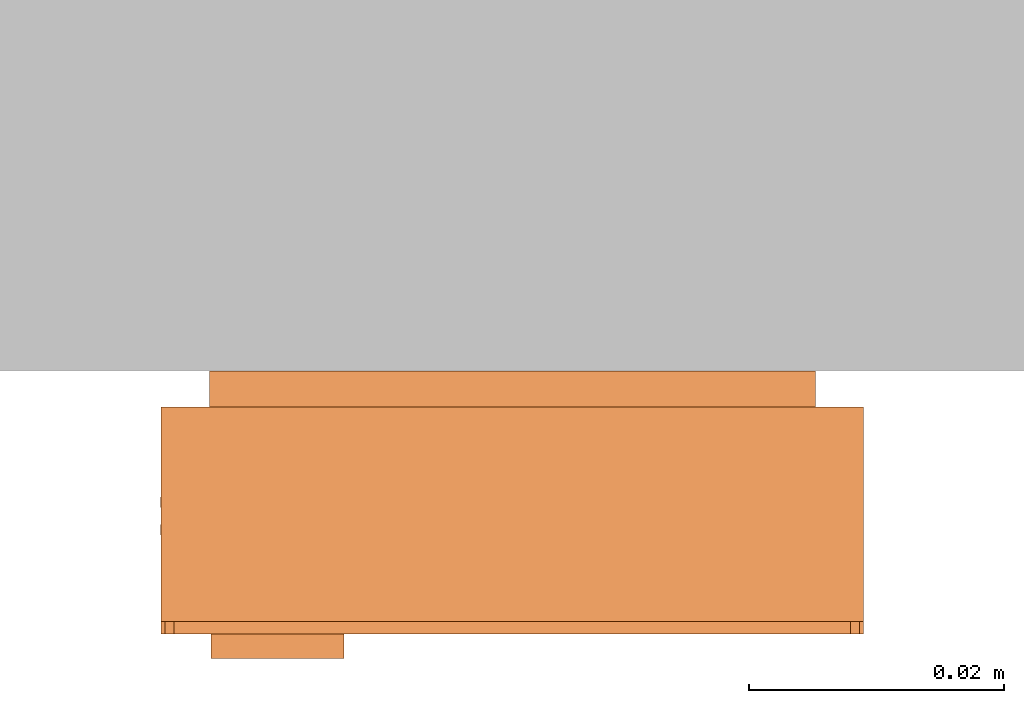
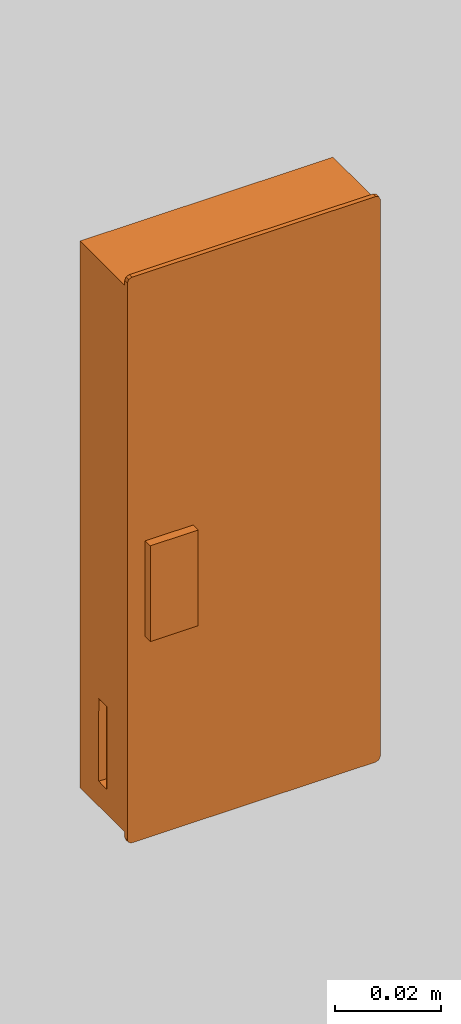
# One storey, part 2 of 2: 1 proxy.
"""IFC2X3 building model written with IfcOpenShell, lengths in metres."""

from ifc_helpers import new_model, entity, si_unit, converted_unit, derived_unit, direction, frame, origin, place, context, subcontext, project, spatial, faceted_brep, source, transform, mapped, material, type_object, type_shapes, element, save


model = new_model("IFC2X3")

# Units and contexts
model_context = context("Model", 3, precision=1e-05, world=origin(), true_north=direction((6.12303176911189e-17, 1.0)))
body_context = subcontext(model_context, "Body", "Model", "MODEL_VIEW")
ifc_project = project(units=[si_unit("LENGTHUNIT", "METRE"), si_unit("AREAUNIT", "SQUARE_METRE"), si_unit("VOLUMEUNIT", "CUBIC_METRE"), converted_unit("PLANEANGLEUNIT", "DEGREE", entity("IfcRatioMeasure", 0.0174532925199433), si_unit("PLANEANGLEUNIT", "RADIAN"), dimensions=[0, 0, 0, 0, 0, 0, 0]), si_unit("MASSUNIT", "GRAM", prefix="KILO"), si_unit("TIMEUNIT", "SECOND"), si_unit("FREQUENCYUNIT", "HERTZ"), si_unit("THERMODYNAMICTEMPERATUREUNIT", "DEGREE_CELSIUS"), derived_unit("THERMALTRANSMITTANCEUNIT", [(si_unit("MASSUNIT", "GRAM", prefix="KILO"), 1), (si_unit("THERMODYNAMICTEMPERATUREUNIT", "KELVIN"), -1), (si_unit("TIMEUNIT", "SECOND"), -3)]), derived_unit("VOLUMETRICFLOWRATEUNIT", [(si_unit("LENGTHUNIT", "METRE"), 3), (si_unit("TIMEUNIT", "SECOND"), -1)]), si_unit("ELECTRICCURRENTUNIT", "AMPERE"), si_unit("ELECTRICVOLTAGEUNIT", "VOLT"), si_unit("POWERUNIT", "WATT"), si_unit("FORCEUNIT", "NEWTON", prefix="KILO"), si_unit("ILLUMINANCEUNIT", "LUX"), si_unit("LUMINOUSFLUXUNIT", "LUMEN"), si_unit("LUMINOUSINTENSITYUNIT", "CANDELA"), derived_unit("USERDEFINED", [(si_unit("MASSUNIT", "GRAM", prefix="KILO"), -1), (si_unit("LENGTHUNIT", "METRE"), -2), (si_unit("TIMEUNIT", "SECOND"), 3), (si_unit("LUMINOUSFLUXUNIT", "LUMEN"), 1)]), derived_unit("LINEARVELOCITYUNIT", [(si_unit("LENGTHUNIT", "METRE"), 1), (si_unit("TIMEUNIT", "SECOND"), -1)]), si_unit("PRESSUREUNIT", "PASCAL"), derived_unit("USERDEFINED", [(si_unit("LENGTHUNIT", "METRE"), -2), (si_unit("MASSUNIT", "GRAM", prefix="KILO"), 1), (si_unit("TIMEUNIT", "SECOND"), -2)])], contexts=[model_context])

# Site, building, storey
site_placement = place(None, origin())
site = spatial("IfcSite", under=ifc_project, at=site_placement, CompositionType="ELEMENT")
building_placement = place(site_placement, origin())
building = spatial("IfcBuilding", under=site, at=building_placement, CompositionType="ELEMENT")
storey_placement = place(building_placement, origin())
storey = spatial("IfcBuildingStorey", under=building, at=storey_placement, Name="Ebene 0", CompositionType="ELEMENT", Elevation=0.0)

# Proxy
ifc_material = material(Name="Color aluminum")
building_element_proxy_type = type_object("IfcBuildingElementProxyType", Name="123926", PredefinedType="NOTDEFINED", material=ifc_material)
shared_shape = source(origin(), body_context, "Body", "Brep", [
    faceted_brep([(-0.0131999998092463, -0.0186000041961923, 0.0224999999999981), (-0.0131999998092463, -0.00859402157550463, 0.0224999999999981), (-0.0131999998092464, 0.00339999580380773, 0.0224999999999981), (-0.0236053290845589, 0.00339999580380773, 0.0224999999999981), (-0.0236053290845589, -0.0186000041961923, 0.0224999999999981), (-0.0131999998092463, -0.0186000041961923, 0.0205999999999981), (-0.0236053290845589, -0.0186000041961923, 0.0205999999999981), (-0.0236053290845589, 0.00339999580380772, 0.0205999999999981), (-0.0131999998092464, 0.00339999580380773, 0.0205999999999981), (-0.0131999998092463, -0.00859402157550463, 0.0205999999999981)], [[[0, 1, 2, 3, 4]], [[5, 6, 7, 8, 9]], [[1, 0, 5, 9]], [[2, 1, 9, 8]], [[3, 2, 8, 7]], [[4, 3, 7, 6]], [[0, 4, 6, 5]]]),
    faceted_brep([(0.0275000000000188, 0.0639999999999747, 0.0205999999999981), (0.0272071067812053, 0.0647071067811613, 0.0205999999999981), (0.0265000000000188, 0.0649999999999747, 0.0205999999999981), (-0.0264999999999813, 0.0649999999999747, 0.0205999999999981), (-0.0272071067811678, 0.0647071067811613, 0.0205999999999981), (-0.0274999999999812, 0.0639999999999747, 0.0205999999999981), (-0.0274999999999812, -0.0640000000000253, 0.0205999999999981), (-0.0272071067811678, -0.0647071067812118, 0.0205999999999981), (-0.0264999999999812, -0.0650000000000253, 0.0205999999999981), (0.0265000000000188, -0.0650000000000253, 0.0205999999999981), (0.0272071067812053, -0.0647071067812118, 0.0205999999999981), (0.0275000000000188, -0.0640000000000253, 0.0205999999999981), (-0.0274999999999813, 0.0639999999999747, 0.0195999999999981), (-0.0272071067811678, 0.0647071067811613, 0.0195999999999981), (-0.0264999999999813, 0.0649999999999747, 0.0195999999999981), (0.0265000000000188, 0.0649999999999747, 0.0195999999999981), (0.0272071067812053, 0.0647071067811613, 0.0195999999999981), (0.0275000000000188, 0.0639999999999747, 0.0195999999999981), (0.0275000000000188, -0.0640000000000253, 0.0195999999999981), (0.0272071067812053, -0.0647071067812118, 0.0195999999999981), (0.0265000000000188, -0.0650000000000253, 0.0195999999999981), (-0.0264999999999812, -0.0650000000000253, 0.0195999999999981), (-0.0272071067811678, -0.0647071067812118, 0.0195999999999981), (-0.0274999999999812, -0.0640000000000253, 0.0195999999999981)], [[[0, 1, 2, 3, 4, 5, 6, 7, 8, 9, 10, 11]], [[12, 13, 14, 15, 16, 17, 18, 19, 20, 21, 22, 23]], [[3, 2, 15, 14]], [[3, 14, 13, 4]], [[13, 12, 5, 4]], [[6, 5, 12, 23]], [[6, 23, 22, 7]], [[22, 21, 8, 7]], [[9, 8, 21, 20]], [[9, 20, 19, 10]], [[19, 18, 11, 10]], [[0, 11, 18, 17]], [[0, 17, 16, 1]], [[16, 15, 2, 1]]]),
    faceted_brep([(0.00595327290728861, 0.0323987510346145, 0.00199999999999813), (0.00669715479099942, 0.0323171332573382, 0.00199999999999813), (0.00739780763980555, 0.0320542505763938, 0.00199999999999813), (0.00801178551193202, 0.0316264037685061, 0.00199999999999813), (0.00850101699022983, 0.0310601226730038, 0.00199999999999813), (0.00883516590699932, 0.0303905211348467, 0.00199999999999813), (0.00899351242301216, 0.0296591196723466, 0.00199999999999813), (0.00896623781915989, 0.0289112708811693, 0.00199999999999813), (0.00875503333362548, 0.0281933472196489, 0.00199999999999813), (0.00837299529192415, 0.0275498655546625, 0.00199999999999813), (0.00784381303256908, 0.0270207267686484, 0.00199999999999813), (0.00720029998330481, 0.0266387415936648, 0.00199999999999813), (0.00648235897263965, 0.026427596090076, 0.00199999999999813), (0.00573450794323291, 0.0264003829260567, 0.00199999999999813), (0.00500311949220646, 0.0265587895300408, 0.00199999999999813), (0.00433354540841312, 0.026892993456997, 0.00199999999999813), (0.00376730450778022, 0.0273822714566364, 0.00199999999999813), (0.0033395081428717, 0.0279962844765732, 0.00199999999999813), (-0.00046539388874918, 0.0281909146064386, 0.00199999999999813), (-0.00426179813546751, 0.0278707972011297, 0.00199999999999813), (-0.00631916904690422, 0.0293824233008529, 0.00199999999999813), (-0.004807542947181, 0.0314397942122896, 0.00199999999999813), (-0.000448124799457331, 0.0318020802939934, 0.00199999999999813), (0.00391977045638956, 0.0315627712351405, 0.00199999999999813), (0.00452014828752698, 0.0320095017784878, 0.00199999999999813), (0.00521228846780218, 0.0322940429694063, 0.00199999999999813), (-0.0109945645357054, 0.0103573613437957, 0.00199999999999813), (-0.00806801483164894, 0.0127695929368891, 0.00199999999999813), (-0.00463283502951686, 0.0143767936574138, 0.00199999999999813), (-0.000905588419798908, 0.0150776411011397, 0.00199999999999813), (0.00287874900301226, 0.0148279518956419, 0.00199999999999813), (0.006481602080755, 0.0136434671430043, 0.00199999999999813), (0.00967583693322232, 0.0115988600569572, 0.00199999999999813), (0.0122600801097966, 0.00882302835576193, 0.00199999999999813), (0.0140714137319444, 0.00549096819149296, 0.00199999999999813), (0.0149956462894735, 0.00181274190581743, 0.00199999999999813), (0.0149745115909864, -0.00197976488436121, 0.00199999999999813), (0.0140093420266668, -0.00564746200123745, 0.00199999999999813), (0.0121609845706963, -0.00895912761599833, 0.00199999999999813), (0.00954596481874181, -0.0117059851161099, 0.00199999999999813), (0.0063291408902611, -0.0137148649637327, 0.00199999999999813), (0.00271331031406049, -0.0148591217850993, 0.00199999999999813), (-0.00107357489205029, -0.0150666184471703, 0.00199999999999813), (-0.0047927789505631, -0.0143242737831678, 0.00199999999999813), (-0.00820983289178552, -0.0126788872657174, 0.00199999999999813), (-0.0111093161299209, -0.0102341886379101, 0.00199999999999813), (-0.00647441451176878, -0.0264263218544691, 0.00199999999999813), (-0.00572809606986997, -0.0264009652476672, 0.00199999999999813), (-0.00499856591246103, -0.0265604015159931, 0.00199999999999813), (-0.00433086774237302, -0.026894786515489, 0.00199999999999813), (-0.00376622754272511, -0.0273834741653926, 0.00199999999999813), (-0.0033395081428342, -0.0279962912082233, 0.00199999999999813), (0.000465393888786651, -0.0281909213380886, 0.00199999999999813), (0.004261798135505, -0.0278708039327798, 0.00199999999999813), (0.00631916904694167, -0.0293824300325027, 0.00199999999999813), (0.00481130237345541, -0.0314643863925102, 0.00199999999999813), (0.000438255833877583, -0.0318270981374608, 0.00199999999999813), (-0.00394311978615621, -0.0315849338886308, 0.00199999999999813), (-0.00454683893134688, -0.0320244306098438, 0.00199999999999813), (-0.00524028124243611, -0.0323015080997595, 0.00199999999999813), (-0.00598063120443257, -0.0323990586404993, 0.00199999999999813), (-0.00672217706253015, -0.0323110591259261, 0.00199999999999813), (-0.00741913322318138, -0.0320429429489486, 0.00199999999999813), (-0.00802846721422893, -0.0316112645251412, 0.00199999999999813), (-0.00851255665784666, -0.0310426771661499, 0.00199999999999813), (-0.00884151220563613, -0.0303722874124952, 0.00199999999999813), (-0.00899502300987054, -0.0296414874349294, 0.00199999999999813), (-0.00896361078513965, -0.0288953993393507, 0.00199999999999813), (-0.00874921503031362, -0.0281800891726822, 0.00199999999999813), (-0.00836507327720733, -0.0275397226465839, 0.00199999999999813), (-0.00783490375980494, -0.0270138381944044, 0.00199999999999813), (-0.00719144096885974, -0.0266349057322218, 0.00199999999999813), (0.00687148039924862, -0.0488742246955457, 0.00199999999999813), (0.013128519600789, -0.0488742246955457, 0.00199999999999813), (0.0146689406874818, -0.0495994925205039, 0.00199999999999813), (0.015089701956535, -0.051250003365825, 0.00199999999999813), (0.0146689406874818, -0.0529005142111462, 0.00199999999999813), (0.013128519600789, -0.0536257820361043, 0.00199999999999813), (0.00687148039924859, -0.0536257820361044, 0.00199999999999813), (0.00533105931255572, -0.0529005142111462, 0.00199999999999813), (0.0049102980435025, -0.051250003365825, 0.00199999999999813), (0.00533105931255575, -0.0495994925205038, 0.00199999999999813), (-0.0182499999999812, 0.0540896985906913, 0.00199999999999813), (-0.01659948915466, 0.053668937321638, 0.00199999999999813), (-0.0158742213297019, 0.0521285162349452, 0.00199999999999813), (-0.0158742213297019, 0.0458714770334049, 0.00199999999999813), (-0.0165994891546601, 0.044331055946712, 0.00199999999999813), (-0.0182499999999813, 0.0439102946776588, 0.00199999999999813), (-0.0199005108453024, 0.0443310559467121, 0.00199999999999813), (-0.0206257786702606, 0.0458714770334049, 0.00199999999999813), (-0.0206257786702606, 0.0521285162349452, 0.00199999999999813), (-0.0199005108453024, 0.053668937321638, 0.00199999999999813), (-0.0237363485327666, 0.0573553257187527, 0.00279999999999813), (-0.0237363485327666, -0.0574863518986104, 0.00279999999999813), (0.0237363485328041, -0.0574863518986105, 0.00279999999999813), (0.0237363485328041, 0.0573553257187527, 0.00279999999999813), (0.0237363485328041, -0.0574863518986105, 0.0), (0.0146689406874818, -0.0529005142111462, 0.0), (0.015089701956535, -0.0512500033658251, 0.0), (0.0131285196007889, -0.0536257820361044, 0.0), (0.0146689406874818, -0.0495994925205039, 0.0), (0.00687148039924859, -0.0536257820361044, 0.0), (0.0121609845706963, -0.0089591276159983, 0.0), (0.0140093420266668, -0.0056474620012374, 0.0), (0.0149745115909864, -0.00197976488436115, 0.0), (0.0149956462894735, 0.00181274190581749, 0.0), (0.0237363485328041, 0.0573553257187527, 0.0), (-0.0237363485327666, -0.0574863518986104, 0.0), (0.00533105931255571, -0.0529005142111462, 0.0), (0.00491029804350251, -0.051250003365825, 0.0), (-0.00672217706253036, -0.0323110591259261, 0.0), (-0.00741913322318156, -0.0320429429489485, 0.0), (-0.00802846721422907, -0.031611264525141, 0.0), (-0.00851255665784676, -0.0310426771661498, 0.0), (-0.00884151220563619, -0.030372287412495, 0.0), (-0.00899502300987055, -0.0296414874349293, 0.0), (-0.00896361078513963, -0.0288953993393506, 0.0), (-0.0111093161299209, -0.0102341886379101, 0.0), (-0.0206257786702606, 0.0458714770334049, 0.0), (-0.0237363485327666, 0.0573553257187527, 0.0), (-0.0206257786702606, 0.0521285162349452, 0.0), (-0.0199005108453024, 0.053668937321638, 0.0), (-0.0182499999999812, 0.0540896985906913, 0.0), (-0.01659948915466, 0.053668937321638, 0.0), (0.0140714137319444, 0.00549096819149301, 0.0), (0.00896623781915989, 0.0289112708811693, 0.0), (0.00899351242301216, 0.0296591196723466, 0.0), (0.00883516590699932, 0.0303905211348467, 0.0), (0.00850101699022982, 0.0310601226730038, 0.0), (0.00801178551193201, 0.0316264037685061, 0.0), (0.00739780763980554, 0.0320542505763938, 0.0), (0.0066971547909994, 0.0323171332573382, 0.0), (0.0059532729072886, 0.0323987510346145, 0.0), (-0.0158742213297019, 0.0521285162349452, 0.0), (0.00521228846780217, 0.0322940429694062, 0.0), (-0.0158742213297019, 0.0458714770334049, 0.0), (-0.0109945645357054, 0.0103573613437957, 0.0), (-0.0199005108453024, 0.0443310559467121, 0.0), (-0.00631916904690425, 0.0293824233008531, 0.0), (-0.0182499999999813, 0.0439102946776588, 0.0), (-0.0165994891546601, 0.044331055946712, 0.0), (-0.004807542947181, 0.0314397942122897, 0.0), (-0.000448124799457327, 0.0318020802939934, 0.0), (-0.00806801483164902, 0.0127695929368891, 0.0), (-0.00426179813546804, 0.0278707972011296, 0.0), (-0.00463283502951695, 0.0143767936574138, 0.0), (-0.000905588419798997, 0.0150776411011397, 0.0), (-0.000465393888749356, 0.0281909146064386, 0.0), (0.00433354540841313, 0.026892993456997, 0.0), (0.00376730450778022, 0.0273822714566364, 0.0), (0.0033395081428719, 0.0279962844765732, 0.0), (0.00287874900301219, 0.0148279518956419, 0.0), (0.00500311949220647, 0.0265587895300408, 0.0), (0.00573450794323292, 0.0264003829260567, 0.0), (0.00648235897263966, 0.026427596090076, 0.0), (0.00648160208075493, 0.0136434671430044, 0.0), (0.00720029998330482, 0.0266387415936648, 0.0), (0.00784381303256909, 0.0270207267686484, 0.0), (0.00967583693322227, 0.0115988600569572, 0.0), (0.00837299529192415, 0.0275498655546625, 0.0), (0.00875503333362548, 0.0281933472196489, 0.0), (0.0122600801097966, 0.00882302835576198, 0.0), (-0.00874921503031357, -0.0281800891726821, 0.0), (-0.00836507327720726, -0.0275397226465838, 0.0), (-0.00820983289178552, -0.0126788872657174, 0.0), (-0.00783490375980487, -0.0270138381944044, 0.0), (-0.00719144096885967, -0.0266349057322218, 0.0), (-0.00479277895056308, -0.0143242737831678, 0.0), (-0.00647441451176871, -0.0264263218544691, 0.0), (-0.00572809606986991, -0.0264009652476672, 0.0), (-0.00107357489205026, -0.0150666184471703, 0.0), (-0.004998565912461, -0.0265604015159931, 0.0), (-0.004330867742373, -0.026894786515489, 0.0), (0.000465393888786495, -0.0281909213380886, 0.0), (0.00271331031406051, -0.0148591217850993, 0.0), (0.004261798135505, -0.0278708039327797, 0.0), (0.00632914089026112, -0.0137148649637327, 0.0), (0.00631916904694169, -0.0293824300325028, 0.0), (0.00954596481874183, -0.0117059851161099, 0.0), (0.013128519600789, -0.0488742246955457, 0.0), (0.00480754294721887, -0.0314398009439396, 0.0), (-0.0037662275427251, -0.0273834741653926, 0.0), (-0.00333950814283437, -0.0279962912082233, 0.0), (0.00533105931255576, -0.0495994925205038, 0.0), (-0.0059806312044328, -0.0323990586404992, 0.0), (-0.00524028124243635, -0.0323015080997596, 0.0), (0.000438255833877164, -0.0318270981374608, 0.0), (-0.0045468389313471, -0.0320244306098439, 0.0), (-0.0039431197861567, -0.0315849338886308, 0.0), (0.00687148039924862, -0.0488742246955457, 0.0), (0.00452014828752697, 0.0320095017784878, 0.0), (0.00391977045638956, 0.0315627712351405, 0.0), (0.0050102513996264, -0.0523536563151563, 0.000999999762871913), (0.00563912259747785, -0.0532008202406394, 0.000999999941384827), (0.00687148039924859, -0.0536257820361044, 0.0013259697234142), (0.00491029804350251, -0.051250003365825, 0.00067403020104481), (0.0049102980435025, -0.051250003365825, 0.00132596974176088), (0.0131285196007889, -0.0536257820361044, 0.000674030201044815), (0.0141928341438495, -0.0533190394658334, 0.000999999762871897), (0.0149054722964996, -0.0525410973317884, 0.000999999941384833), (0.015089701956535, -0.0512500033658251, 0.0013259697234142), (0.015089701956535, -0.051250003365825, 0.000674030201044813), (0.0149897486004111, -0.0501463504164937, 0.000999999762871908), (0.0143608774025597, -0.0492991864910106, 0.000999999941384831), (0.013128519600789, -0.0488742246955457, 0.0013259697391777), (0.00687148039924862, -0.0488742246955457, 0.000674030201044818), (0.00580716585618807, -0.0491809672658167, 0.000999999762871896), (0.00509452770353792, -0.0499589093998616, 0.000999999941384833), (-0.0193536529493125, 0.0539897452345674, 0.000999999762871905), (-0.0202008168747956, 0.0533608740367159, 0.000999999941384832), (-0.0206257786702606, 0.0521285162349452, 0.00132596975442457), (-0.0182499999999812, 0.0540896985906913, 0.000674030201044818), (-0.0182499999999812, 0.0540896985906913, 0.0013259697117838), (-0.0206257786702606, 0.0458714770334049, 0.000674030201044818), (-0.0203190360999896, 0.0448071624903444, 0.000999999762871896), (-0.0195410939659446, 0.0440945243376942, 0.000999999941384834), (-0.0182499999999813, 0.0439102946776588, 0.00132596973969434), (-0.0182499999999813, 0.0439102946776588, 0.000674030201044819), (-0.0171463470506499, 0.0440102480337827, 0.000999999762871906), (-0.0162991831251669, 0.0446391192316341, 0.000999999941384832), (-0.0158742213297019, 0.0458714770334049, 0.00132596975545783), (-0.0158742213297019, 0.0521285162349452, 0.000674030201044818), (-0.0161809638999729, 0.0531928307780057, 0.000999999762871897), (-0.0169589060340179, 0.0539054689306559, 0.000999999941384833)], [[[0, 1, 2, 3, 4, 5, 6, 7, 8, 9, 10, 11, 12, 13, 14, 15, 16, 17, 18, 19, 20, 21, 22, 23, 24, 25]], [[26, 27, 28, 29, 30, 31, 32, 33, 34, 35, 36, 37, 38, 39, 40, 41, 42, 43, 44, 45]], [[46, 47, 48, 49, 50, 51, 52, 53, 54, 55, 56, 57, 58, 59, 60, 61, 62, 63, 64, 65, 66, 67, 68, 69, 70, 71]], [[72, 73, 74, 75, 76, 77, 78, 79, 80, 81]], [[82, 83, 84, 85, 86, 87, 88, 89, 90, 91]], [[92, 93, 94, 95]], [[96, 97, 98]], [[97, 96, 99]], [[96, 98, 100]], [[96, 101, 99]], [[96, 100, 102]], [[102, 103, 96]], [[104, 96, 103]], [[104, 105, 96]], [[96, 105, 106]], [[96, 107, 101]], [[108, 101, 107]], [[108, 107, 109]], [[110, 109, 107]], [[111, 110, 107]], [[112, 111, 107]], [[107, 113, 112]], [[113, 107, 114]], [[114, 107, 115]], [[116, 115, 107]], [[116, 107, 117]], [[107, 118, 117]], [[107, 119, 118]], [[119, 120, 118]], [[121, 120, 119]], [[121, 119, 122]], [[123, 122, 119]], [[123, 119, 106]], [[105, 124, 106]], [[125, 106, 124]], [[125, 126, 106]], [[127, 106, 126]], [[106, 127, 128]], [[106, 128, 129]], [[129, 130, 106]], [[130, 131, 106]], [[106, 131, 132]], [[106, 132, 133]], [[123, 106, 133]], [[133, 132, 134]], [[133, 134, 135]], [[136, 117, 118]], [[137, 136, 118]], [[136, 137, 138]], [[139, 138, 137]], [[138, 139, 140]], [[141, 138, 140]], [[140, 135, 141]], [[142, 141, 135]], [[143, 136, 138]], [[143, 138, 144]], [[145, 143, 144]], [[144, 146, 145]], [[144, 147, 146]], [[148, 146, 147]], [[149, 148, 147]], [[147, 150, 149]], [[146, 148, 151]], [[152, 151, 148]], [[151, 152, 153]], [[153, 154, 151]], [[151, 154, 155]], [[155, 154, 156]], [[156, 157, 155]], [[158, 155, 157]], [[159, 158, 157]], [[158, 159, 160]], [[161, 158, 160]], [[160, 125, 161]], [[124, 161, 125]], [[117, 162, 116]], [[163, 162, 117]], [[164, 163, 117]], [[165, 163, 164]], [[166, 165, 164]], [[167, 166, 164]], [[168, 166, 167]], [[169, 168, 167]], [[167, 170, 169]], [[171, 169, 170]], [[170, 172, 171]], [[173, 172, 170]], [[173, 170, 174]], [[173, 174, 175]], [[175, 174, 176]], [[175, 176, 177]], [[176, 178, 177]], [[102, 177, 178]], [[177, 100, 179]], [[102, 100, 177]], [[180, 177, 179]], [[181, 172, 173]], [[182, 181, 173]], [[109, 110, 183]], [[184, 183, 110]], [[184, 185, 183]], [[186, 183, 185]], [[185, 187, 186]], [[188, 186, 187]], [[186, 189, 183]], [[189, 186, 180]], [[179, 189, 180]], [[142, 134, 190]], [[134, 142, 135]], [[142, 190, 191]], [[94, 93, 107, 96]], [[95, 94, 96, 106]], [[92, 95, 106, 119]], [[93, 92, 119, 107]], [[117, 136, 26, 45]], [[117, 45, 44, 164]], [[167, 43, 42, 170]], [[167, 164, 44, 43]], [[174, 170, 42, 41]], [[178, 176, 40, 39]], [[103, 102, 38, 37]], [[38, 102, 178, 39]], [[40, 176, 174, 41]], [[103, 37, 36, 104]], [[36, 35, 105, 104]], [[105, 35, 34, 124]], [[161, 33, 32, 158]], [[161, 124, 34, 33]], [[155, 158, 32, 31]], [[146, 151, 30, 29]], [[143, 145, 28, 27]], [[28, 145, 146, 29]], [[30, 151, 155, 31]], [[143, 27, 26, 136]], [[53, 52, 173, 175]], [[173, 52, 51, 182]], [[182, 51, 50, 181]], [[172, 49, 48, 171]], [[172, 181, 50, 49]], [[169, 171, 48, 47]], [[166, 168, 46, 71]], [[163, 165, 70, 69]], [[70, 165, 166, 71]], [[46, 168, 169, 47]], [[163, 69, 68, 162]], [[67, 116, 162, 68]], [[116, 67, 66, 115]], [[114, 65, 64, 113]], [[114, 115, 66, 65]], [[112, 113, 64, 63]], [[110, 111, 62, 61]], [[185, 184, 60, 59]], [[60, 184, 110, 61]], [[62, 111, 112, 63]], [[185, 59, 58, 187]], [[58, 57, 188, 187]], [[56, 186, 188, 57]], [[55, 180, 186]], [[56, 55, 186]], [[54, 180, 55]], [[177, 180, 54]], [[53, 175, 177, 54]], [[109, 192, 108]], [[101, 193, 78, 194]], [[80, 79, 192]], [[193, 108, 192]], [[192, 109, 195, 196, 80]], [[193, 192, 79]], [[78, 193, 79]], [[101, 108, 193]], [[77, 197, 99, 101, 194, 78]], [[99, 198, 97]], [[199, 75, 200, 201, 98]], [[77, 76, 198]], [[199, 97, 198]], [[77, 198, 99, 197]], [[199, 198, 76]], [[75, 199, 76]], [[98, 97, 199]], [[98, 202, 100]], [[179, 203, 73, 204]], [[75, 74, 202]], [[203, 100, 202]], [[202, 98, 201, 200, 75]], [[203, 202, 74]], [[73, 203, 74]], [[179, 100, 203]], [[73, 72, 205, 189, 179, 204]], [[189, 206, 183]], [[207, 80, 196, 195, 109]], [[72, 81, 206]], [[207, 183, 206]], [[72, 206, 189, 205]], [[207, 206, 81]], [[80, 207, 81]], [[109, 183, 207]], [[22, 142, 191, 23]], [[21, 141, 142, 22]], [[20, 138, 141, 21]], [[19, 144, 138, 20]], [[19, 18, 147, 144]], [[147, 18, 17, 150]], [[150, 17, 16, 149]], [[148, 15, 14, 152]], [[148, 149, 16, 15]], [[153, 152, 14, 13]], [[156, 154, 12, 11]], [[159, 157, 10, 9]], [[10, 157, 156, 11]], [[12, 154, 153, 13]], [[159, 9, 8, 160]], [[7, 125, 160, 8]], [[125, 7, 6, 126]], [[127, 5, 4, 128]], [[127, 126, 6, 5]], [[129, 128, 4, 3]], [[131, 130, 2, 1]], [[134, 132, 0, 25]], [[0, 132, 131, 1]], [[2, 130, 129, 3]], [[134, 25, 24, 190]], [[24, 23, 191, 190]], [[122, 208, 121]], [[120, 209, 90, 210]], [[82, 91, 208]], [[209, 121, 208]], [[208, 122, 211, 212, 82]], [[209, 208, 91]], [[90, 209, 91]], [[120, 121, 209]], [[90, 89, 213, 118, 120, 210]], [[118, 214, 137]], [[215, 87, 216, 217, 139]], [[89, 88, 214]], [[215, 137, 214]], [[89, 214, 118, 213]], [[215, 214, 88]], [[87, 215, 88]], [[139, 137, 215]], [[139, 218, 140]], [[135, 219, 85, 220]], [[87, 86, 218]], [[219, 140, 218]], [[218, 139, 217, 216, 87]], [[219, 218, 86]], [[85, 219, 86]], [[135, 140, 219]], [[85, 84, 221, 133, 135, 220]], [[133, 222, 123]], [[223, 82, 212, 211, 122]], [[84, 83, 222]], [[223, 123, 222]], [[84, 222, 133, 221]], [[223, 222, 83]], [[82, 223, 83]], [[122, 123, 223]]]),
    faceted_brep([(0.0275000000000188, 0.0629072233411938, 0.0195999999999981), (-0.0274999999999812, 0.0629072233411938, 0.0195999999999981), (-0.0274999999999812, -0.0627609245286139, 0.0195999999999981), (0.0275000000000188, -0.0630019725739416, 0.0195999999999981), (0.0275000000000188, 0.0629072233411938, 0.00279999999999813), (0.0275000000000188, -0.0630019725739416, 0.00279999999999813), (-0.0274999999999812, -0.0627609245286139, 0.00279999999999813), (-0.0274999999999812, 0.0629072233411938, 0.00279999999999813), (-0.0274999999999812, -0.0380019725739416, 0.0128540198723327), (-0.0274999999999812, -0.0570019725739416, 0.0128540198723327), (-0.0274999999999812, -0.0570019725739416, 0.00985401987233275), (-0.0274999999999812, -0.0380019725739416, 0.00985401987233274), (-0.00179904729010734, -0.0628735638815917, 0.0171651714612023), (0.00179904729012024, -0.0628893332209638, 0.0171651714612023), (0.00179904729012088, -0.0628893332209638, 0.0152195987422479), (-0.00179904729010734, -0.0628735638815917, 0.0152195987422479), (-0.00650000004553474, -0.0628529610548121, 0.0112864250068784), (0.00705634356701296, -0.0629123743298957, 0.0112864250068784), (0.00705634356701303, -0.0629123743298957, 0.00893330051291126), (-0.00650000004553475, -0.0628529610548121, 0.00893330051291126), (0.0275000000000188, -0.0570019725739416, 0.0128540198723322), (0.0275000000000188, -0.0380019725739416, 0.0128540198723322), (0.0275000000000188, -0.0380019725739416, 0.00985401987233218), (0.0275000000000188, -0.0570019725739416, 0.00985401987233218), (0.00179904729012023, -0.0589006885984465, 0.0171651714612024), (-0.00179904729010734, -0.0589006885984465, 0.0171651714612024), (-0.00179904729010734, -0.0589006885984465, 0.015219598742248), (0.00179904729012023, -0.0589006885984465, 0.015219598742248), (-0.00650000004553474, -0.0589006885984464, 0.0112864250068784), (0.00705634356701296, -0.0589006885984464, 0.0112864250068784), (-0.00650000004553475, -0.0589006885984464, 0.00893330051291131), (0.00705634356701296, -0.0589006885984464, 0.00893330051291131), (-0.0275499999999812, -0.0380019725739416, 0.0128540198723327), (-0.0275499999999812, -0.0570019725739416, 0.0128540198723327), (-0.0275499999999812, -0.0570019725739416, 0.00985401987233275), (-0.0275499999999812, -0.0380019725739416, 0.00985401987233275)], [[[0, 1, 2, 3]], [[4, 5, 6, 7]], [[1, 0, 4, 7]], [[2, 1, 7, 6], [8, 9, 10, 11]], [[3, 2, 6, 5], [12, 13, 14, 15], [16, 17, 18, 19]], [[0, 3, 5, 4], [20, 21, 22, 23]], [[24, 25, 26, 27]], [[25, 24, 13, 12]], [[26, 25, 12, 15]], [[27, 26, 15, 14]], [[24, 27, 14, 13]], [[28, 29, 17, 16]], [[30, 28, 16, 19]], [[31, 30, 19, 18]], [[29, 31, 18, 17]], [[20, 9, 32, 21]], [[33, 20, 23, 10]], [[34, 23, 22, 11]], [[21, 8, 35, 22]], [[29, 28, 30, 31]]]),
])
type_shapes(building_element_proxy_type, [shared_shape])
proxy_placement = place(storey_placement, frame((-5.30698527669081, 3.99032933236062, 1.60567601915582), z_axis=(0.0, -1.0, 0.0), x_axis=(1.0, 0.0, 0.0)))
element("IfcBuildingElementProxy", 1, at=proxy_placement, inside=storey, type_object=building_element_proxy_type, material=ifc_material, ObjectType="123926", context=body_context, shape_type="MappedRepresentation", body=[
    mapped(shared_shape, transform((0.0, 0.0, 0.0), scale=1.0)),
])

save(model, "model.ifc")
